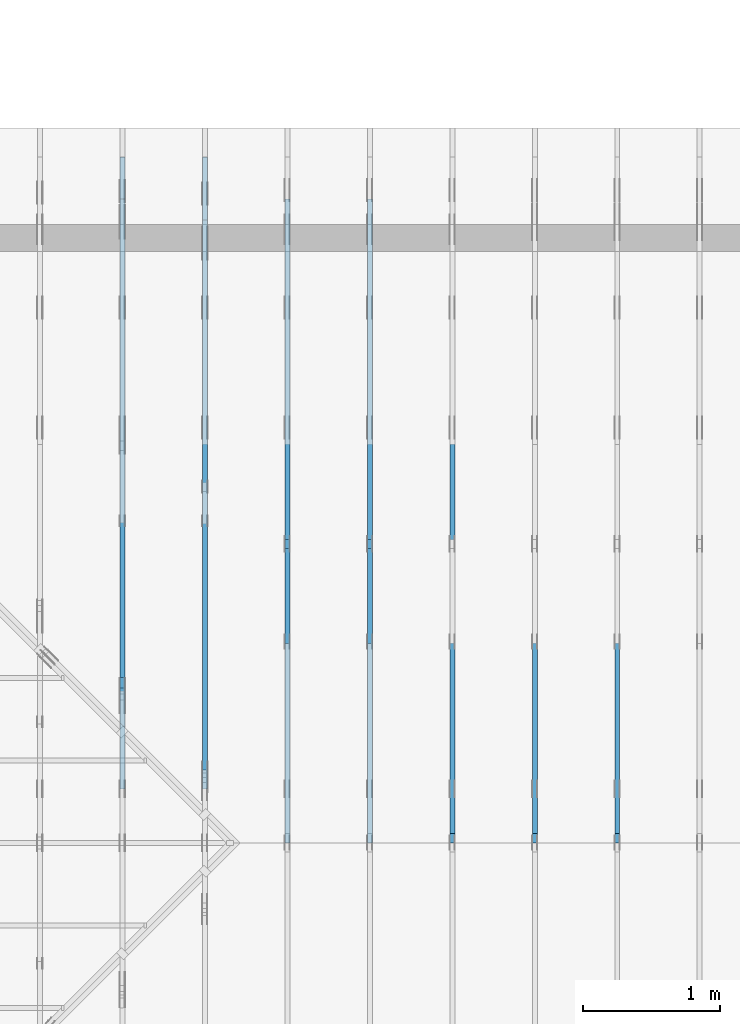
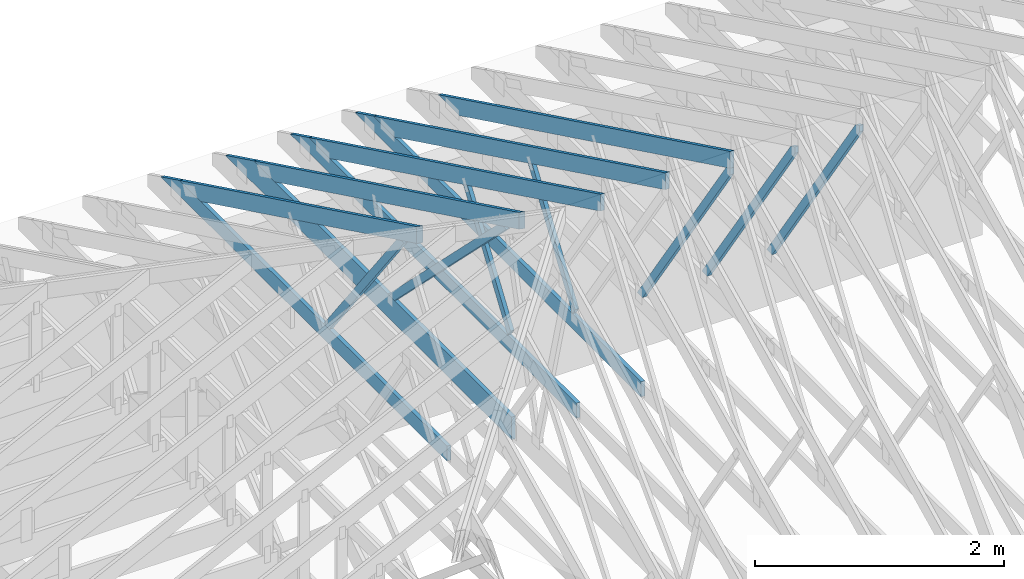
# One storey, part 10 of 159: 16 members, 7 elements without a shape of their own.
"""IFC2X3 building model written with IfcOpenShell, lengths in millimetres."""

from ifc_helpers import new_model, si_unit, frame, origin, origin_with_axes, origin_2d, place, context, project, spatial, faceted_brep, element, aggregate, save


model = new_model("IFC2X3")

# Units and contexts
model_context = context("Model", 3, precision=1e-05, world=origin())
plan_context = context("Plan", 2, precision=1e-05, world=origin_2d())
ifc_project = project(units=[si_unit("LENGTHUNIT", "METRE", prefix="MILLI"), si_unit("AREAUNIT", "SQUARE_METRE"), si_unit("VOLUMEUNIT", "CUBIC_METRE"), si_unit("SOLIDANGLEUNIT", "STERADIAN"), si_unit("PLANEANGLEUNIT", "RADIAN"), si_unit("MASSUNIT", "GRAM"), si_unit("TIMEUNIT", "SECOND"), si_unit("THERMODYNAMICTEMPERATUREUNIT", "DEGREE_CELSIUS"), si_unit("LUMINOUSINTENSITYUNIT", "LUMEN")], contexts=[model_context, plan_context])

# Site, building, storey
site_placement = place(None, origin_with_axes())
site = spatial("IfcSite", under=ifc_project, at=site_placement, CompositionType="ELEMENT")
building_placement = place(site_placement, origin_with_axes())
building = spatial("IfcBuilding", under=site, at=building_placement, Name="Plan 1", CompositionType="ELEMENT")
storey_placement = place(building_placement, origin_with_axes())
storey = spatial("IfcBuildingStorey", under=building, at=storey_placement, Name="Etasje 1", CompositionType="ELEMENT", Elevation=0.0)

# Assembly, member
assembly_1_placement = place(storey_placement, frame((7275.0222614047525, 9699.99999999999, 1.1021457184401395e-15), z_axis=(-1.0, 1.836909530733566e-16, 6.123031769111886e-17), x_axis=(-1.836909530733566e-16, -1.0, 0.0)))
assembly_1 = element("IfcElementAssembly", 1, at=assembly_1_placement, inside=storey, Name="T2 (90)", AssemblyPlace="FACTORY", PredefinedType="TRUSS")
member_1_placement = place(assembly_1_placement, frame((5169.864827117615, 2512.139275987297, -36.0), z_axis=(0.0, 0.0, 1.0), x_axis=(-0.564247505007381, -0.8256056886268078, 0.0)))
member_1 = element("IfcMember", 2, at=member_1_placement, Name="T2-D10", context=model_context, shape_type="Brep", body=[
    faceted_brep([(2543.525473098112, 73.00019205182707, 36.0), (53.406771110823684, 73.00019205182707, 36.0), (0.0, 36.5000932239891, 36.0), (64.12142578859857, 0.00011835385657832376, 36.0), (2593.4163311647667, 0.00011835385657832376, 36.0), (53.406771110823684, 73.00019205182707, 6.540227123945206e-15), (2543.525473098112, 73.00019205182707, 3.114817455465016e-13), (2593.4163311647667, 0.00011835385657832376, 3.175914117251092e-13), (64.12142578859857, 0.00011835385657832376, 7.852350543686785e-15), (0.0, 36.5000932239891, 0.0), (8.990056994662154e-05, 36.50009815631665, 3.944304526105059e-31), (8.990056994662154e-05, 36.50009815631665, 36.0), (53.40680834923387, 73.00009815680099, 36.0), (53.40680834923387, 73.00009815680099, 7.888609052210118e-31), (64.12149423256596, 9.815680185809583e-05, 6.171430365172586e-31), (64.12149423256596, 9.815680186164855e-05, 36.0), (8.990056995195062e-05, 36.50009815631667, 36.0), (8.990056995017426e-05, 36.50009815631666, -3.3878954237129854e-31), (2593.4162640810096, 9.815680364966906e-05, 2.3313020864942917e-30), (2593.4162640810096, 9.815680365187335e-05, 36.0), (64.12149423256596, 9.815680187001689e-05, 36.0), (64.12149423256596, 9.81568018678126e-05, 5.76409767496333e-32), (2543.5255372692222, 73.00009815680278, 0.0), (2543.5255372692222, 73.00009815680278, 36.0), (2593.4162640810096, 9.815680414249073e-05, 36.0), (2593.4162640810096, 9.815680414249073e-05, 0.0), (53.40680834923387, 73.00009815680097, 7.888609052210118e-31), (53.40680834923387, 73.00009815680097, 36.0), (2543.525537269222, 73.00009815680359, 36.0), (2543.525537269222, 73.00009815680359, 4.9698237028923744e-29)], [[[0, 1, 2, 3, 4]], [[5, 6, 7, 8, 9]], [[10, 11, 12, 13]], [[14, 15, 16, 17]], [[18, 19, 20, 21]], [[22, 23, 24, 25]], [[26, 27, 28, 29]]]),
])
aggregate(assembly_1, [member_1])

assembly_2_placement = place(storey_placement, frame((6675.0222614047525, 9699.99999999999, 1.1021457184401395e-15), z_axis=(-1.0, 1.836909530733566e-16, 6.123031769111886e-17), x_axis=(-1.836909530733566e-16, -1.0, 0.0)))
assembly_2 = element("IfcElementAssembly", 3, at=assembly_2_placement, inside=storey, Name="T2 (89)", AssemblyPlace="FACTORY", PredefinedType="TRUSS")
member_2_placement = place(assembly_2_placement, frame((5169.864827117615, 2512.139275987297, -36.0), z_axis=(0.0, 0.0, 1.0), x_axis=(-0.564247505007381, -0.8256056886268078, 0.0)))
member_2 = element("IfcMember", 4, at=member_2_placement, Name="T2-D10", context=model_context, shape_type="Brep", body=[
    faceted_brep([(2543.525473098112, 73.00019205182707, 36.0), (53.406771110823684, 73.00019205182707, 36.0), (0.0, 36.5000932239891, 36.0), (64.12142578859857, 0.00011835385657832376, 36.0), (2593.4163311647667, 0.00011835385657832376, 36.0), (53.406771110823684, 73.00019205182707, 6.540227123945206e-15), (2543.525473098112, 73.00019205182707, 3.114817455465016e-13), (2593.4163311647667, 0.00011835385657832376, 3.175914117251092e-13), (64.12142578859857, 0.00011835385657832376, 7.852350543686785e-15), (0.0, 36.5000932239891, 0.0), (8.990056994662154e-05, 36.50009815631665, 3.944304526105059e-31), (8.990056994662154e-05, 36.50009815631665, 36.0), (53.40680834923387, 73.00009815680099, 36.0), (53.40680834923387, 73.00009815680099, 7.888609052210118e-31), (64.12149423256596, 9.815680185809583e-05, 6.171430365172586e-31), (64.12149423256596, 9.815680186164855e-05, 36.0), (8.990056995195062e-05, 36.50009815631667, 36.0), (8.990056995017426e-05, 36.50009815631666, -3.3878954237129854e-31), (2593.4162640810096, 9.815680364966906e-05, 2.3313020864942917e-30), (2593.4162640810096, 9.815680365187335e-05, 36.0), (64.12149423256596, 9.815680187001689e-05, 36.0), (64.12149423256596, 9.81568018678126e-05, 5.76409767496333e-32), (2543.5255372692222, 73.00009815680278, 0.0), (2543.5255372692222, 73.00009815680278, 36.0), (2593.4162640810096, 9.815680414249073e-05, 36.0), (2593.4162640810096, 9.815680414249073e-05, 0.0), (53.40680834923387, 73.00009815680097, 7.888609052210118e-31), (53.40680834923387, 73.00009815680097, 36.0), (2543.525537269222, 73.00009815680359, 36.0), (2543.525537269222, 73.00009815680359, 4.9698237028923744e-29)], [[[0, 1, 2, 3, 4]], [[5, 6, 7, 8, 9]], [[10, 11, 12, 13]], [[14, 15, 16, 17]], [[18, 19, 20, 21]], [[22, 23, 24, 25]], [[26, 27, 28, 29]]]),
])
aggregate(assembly_2, [member_2])

# Assembly, members
assembly_3_placement = place(storey_placement, frame((5475.0222614047525, 9699.99999999999, 1.1021457184401395e-15), z_axis=(-1.0, 1.836909530733566e-16, 6.123031769111886e-17), x_axis=(-1.836909530733566e-16, -1.0, 0.0)))
assembly_3 = element("IfcElementAssembly", 5, at=assembly_3_placement, inside=storey, Name="T1 (87)", AssemblyPlace="FACTORY", PredefinedType="TRUSS")
member_3_placement = place(assembly_3_placement, frame((579.5051980003889, 237.97847286708455, -36.00000000000001), z_axis=(0.0, 0.0, 1.0), x_axis=(0.8987940462991671, 0.43837114678907757, 0.0)))
member_3 = element("IfcMember", 6, at=member_3_placement, Name="T1-O3", context=model_context, shape_type="Brep", body=[
    faceted_brep([(5212.955369683486, 148.00001471731446, 36.0), (1.573016606926103e-05, 148.00001471731446, 36.0), (303.44498744329735, 0.0, 36.0), (5140.770967673589, 0.0, 36.0), (1.573016606926103e-05, 148.00001471731446, 1.9263261315098228e-21), (5212.955369683486, 148.00001471731446, 6.383818267906877e-13), (5140.770967673589, 0.0, 6.295420790558688e-13), (303.44498744329735, 0.0, 3.716006596586134e-14), (303.44496855236554, 9.213724169399029e-06, 8.404281481000962e-31), (303.44496855236554, 9.213724169399029e-06, 36.0), (0.0, 148.000009213056, 36.0), (0.0, 148.000009213056, -1.9992365007213114e-31), (5140.770891984262, 9.214032787493993e-06, -1.5668329852774188e-28), (5140.770891984262, 9.214032789698284e-06, 36.0), (303.4449685523656, 9.213724336859708e-06, 36.0), (303.4449685523656, 9.213724334655416e-06, -9.24856583218491e-30), (5212.955315091657, 148.00000921330889, -5.793884668474286e-29), (5212.955315091657, 148.00000921330889, 36.0), (5140.770891984262, 9.214030342263868e-06, 36.0), (5140.770891984262, 9.214030342263868e-06, -5.743143320920135e-29), (0.0, 148.000009213056, 0.0), (0.0, 148.000009213056, 36.0), (5212.955315091657, 148.00000921330917, 36.0), (5212.955315091657, 148.00000921330917, 9.466330862652142e-30)], [[[0, 1, 2, 3]], [[4, 5, 6, 7]], [[8, 9, 10, 11]], [[12, 13, 14, 15]], [[16, 17, 18, 19]], [[20, 21, 22, 23]]]),
])
member_4_placement = place(assembly_3_placement, frame((4808.81787109375, 371.0000000000005, -36.0), z_axis=(0.0, 0.0, 1.0), x_axis=(-1.0, 1.2246063538223773e-16, 0.0)))
member_4 = element("IfcMember", 7, at=member_4_placement, Name="T1-U35", context=model_context, shape_type="Brep", body=[
    faceted_brep([(4597.636581420898, 148.00000000000105, 36.0), (0.0, 148.00000000000105, 36.0), (0.0, 5.115907697472721e-13, 36.0), (4294.191589355469, 5.115907697472721e-13, 36.0), (0.0, 148.00000000000105, 0.0), (4597.636581420898, 148.00000000000105, 5.630294970174226e-13), (4294.191589355469, 5.115907697472721e-13, 5.25869430485532e-13), (0.0, 5.115907697472721e-13, 0.0), (0.00023664694708713796, 0.0, 0.0), (0.00023664694708934225, -2.6993892992798474e-31, 36.0), (0.00023664694710746643, 147.99999999999994, 36.0), (0.00023664694710526213, 147.99999999999994, -1.1097479173457682e-30), (4294.191606856883, -7.888042053292689e-13, 1.1094846280734072e-28), (4294.191606856883, -7.865999138923886e-13, 36.0), (0.00023664694708713796, 2.2041915808575547e-15, 36.0), (0.00023664694708713796, -9.985602272457245e-20, 6.114215994797155e-36), (4597.636575412006, 148.00000000000205, -2.5243548967072372e-29), (4597.636575412006, 148.00000000000205, 36.0), (4294.191606856883, 1.5916157281026244e-12, 36.0), (4294.191606856883, 1.5916157281026244e-12, -2.5243548967072372e-29), (0.00023664694708713796, 147.99999999999994, 0.0), (0.00023664694708713796, 147.99999999999994, 36.0), (4597.636575412005, 148.00000000000068, 36.0), (4597.636575412005, 148.00000000000068, -2.208810534618833e-29)], [[[0, 1, 2, 3]], [[4, 5, 6, 7]], [[8, 9, 10, 11]], [[12, 13, 14, 15]], [[16, 17, 18, 19]], [[20, 21, 22, 23]]]),
])
member_5_placement = place(assembly_3_placement, frame((2992.962039007774, 1415.1000197155186, -36.0), z_axis=(0.0, 0.0, 1.0), x_axis=(0.5642475050068997, -0.8256056886271368, 0.0)))
member_5 = element("IfcMember", 8, at=member_5_placement, Name="T1-D42", context=model_context, shape_type="Brep", body=[
    faceted_brep([(1236.1860950310158, 73.0001983605489, 36.0), (10.714657585100667, 73.0001983605489, 36.0), (2.9073682981106685e-06, 0.00014238622361517628, 36.0), (1264.647317839714, 0.00014238622361517628, 36.0), (10.714657585100667, 73.0001983605489, 1.3121237757745405e-15), (1236.1860950310158, 73.0001983605489, 1.513841346481855e-13), (1264.647317839714, 0.00014238622361517628, 1.5486951407709413e-13), (2.9073682981106685e-06, 0.00014238622361517628, 3.560381690768076e-22), (-1.0876495965808294e-15, 9.815680186891362e-05, 6.73106873190455e-32), (1.0932755894164925e-15, 9.815680186859351e-05, 36.0), (10.71468588481117, 73.00009815680141, 36.0), (10.714685884811168, 73.00009815680141, -5.004528960490232e-31), (1264.6473849234712, 9.81568027596822e-05, 5.682548008281813e-29), (1264.6473849234712, 9.815680276188649e-05, 36.0), (-1.5529013882837331e-30, 9.815680187095826e-05, 36.0), (0.0, 9.815680186875397e-05, 0.0), (1236.1860298813824, 73.00009815680414, 0.0), (1236.1860298813824, 73.00009815680414, 36.0), (1264.6473849234712, 9.81568037445868e-05, 36.0), (1264.6473849234712, 9.81568037445868e-05, 1.262177448353619e-29), (10.714685884811162, 73.00009815680141, 0.0), (10.714685884811162, 73.0000981568014, 36.0), (1236.1860298813824, 73.00009815680406, 36.0), (1236.1860298813824, 73.00009815680406, -5.5220263365470826e-30)], [[[0, 1, 2, 3]], [[4, 5, 6, 7]], [[8, 9, 10, 11]], [[12, 13, 14, 15]], [[16, 17, 18, 19]], [[20, 21, 22, 23]]]),
])
aggregate(assembly_3, [member_3, member_4, member_5])

assembly_4_placement = place(storey_placement, frame((4875.0222614047525, 9699.99999999999, 1.1021457184401395e-15), z_axis=(-1.0, 1.836909530733566e-16, 6.123031769111886e-17), x_axis=(-1.836909530733566e-16, -1.0, 0.0)))
assembly_4 = element("IfcElementAssembly", 9, at=assembly_4_placement, inside=storey, Name="T1 (86)", AssemblyPlace="FACTORY", PredefinedType="TRUSS")
member_6_placement = place(assembly_4_placement, frame((579.5051980003889, 237.97847286708455, -36.00000000000001), z_axis=(0.0, 0.0, 1.0), x_axis=(0.8987940462991671, 0.43837114678907757, 0.0)))
member_6 = element("IfcMember", 10, at=member_6_placement, Name="T1-O3", context=model_context, shape_type="Brep", body=[
    faceted_brep([(5212.955369683486, 148.00001471731446, 36.0), (1.573016606926103e-05, 148.00001471731446, 36.0), (303.44498744329735, 0.0, 36.0), (5140.770967673589, 0.0, 36.0), (1.573016606926103e-05, 148.00001471731446, 1.9263261315098228e-21), (5212.955369683486, 148.00001471731446, 6.383818267906877e-13), (5140.770967673589, 0.0, 6.295420790558688e-13), (303.44498744329735, 0.0, 3.716006596586134e-14), (303.44496855236554, 9.213724169399029e-06, 8.404281481000962e-31), (303.44496855236554, 9.213724169399029e-06, 36.0), (0.0, 148.000009213056, 36.0), (0.0, 148.000009213056, -1.9992365007213114e-31), (5140.770891984262, 9.214032787493993e-06, -1.5668329852774188e-28), (5140.770891984262, 9.214032789698284e-06, 36.0), (303.4449685523656, 9.213724336859708e-06, 36.0), (303.4449685523656, 9.213724334655416e-06, -9.24856583218491e-30), (5212.955315091657, 148.00000921330889, -5.793884668474286e-29), (5212.955315091657, 148.00000921330889, 36.0), (5140.770891984262, 9.214030342263868e-06, 36.0), (5140.770891984262, 9.214030342263868e-06, -5.743143320920135e-29), (0.0, 148.000009213056, 0.0), (0.0, 148.000009213056, 36.0), (5212.955315091657, 148.00000921330917, 36.0), (5212.955315091657, 148.00000921330917, 9.466330862652142e-30)], [[[0, 1, 2, 3]], [[4, 5, 6, 7]], [[8, 9, 10, 11]], [[12, 13, 14, 15]], [[16, 17, 18, 19]], [[20, 21, 22, 23]]]),
])
member_7_placement = place(assembly_4_placement, frame((4808.81787109375, 371.0000000000005, -36.0), z_axis=(0.0, 0.0, 1.0), x_axis=(-1.0, 1.2246063538223773e-16, 0.0)))
member_7 = element("IfcMember", 11, at=member_7_placement, Name="T1-U35", context=model_context, shape_type="Brep", body=[
    faceted_brep([(4597.636581420898, 148.00000000000105, 36.0), (0.0, 148.00000000000105, 36.0), (0.0, 5.115907697472721e-13, 36.0), (4294.191589355469, 5.115907697472721e-13, 36.0), (0.0, 148.00000000000105, 0.0), (4597.636581420898, 148.00000000000105, 5.630294970174226e-13), (4294.191589355469, 5.115907697472721e-13, 5.25869430485532e-13), (0.0, 5.115907697472721e-13, 0.0), (0.00023664694708713796, 0.0, 0.0), (0.00023664694708934225, -2.6993892992798474e-31, 36.0), (0.00023664694710746643, 147.99999999999994, 36.0), (0.00023664694710526213, 147.99999999999994, -1.1097479173457682e-30), (4294.191606856883, -7.888042053292689e-13, 1.1094846280734072e-28), (4294.191606856883, -7.865999138923886e-13, 36.0), (0.00023664694708713796, 2.2041915808575547e-15, 36.0), (0.00023664694708713796, -9.985602272457245e-20, 6.114215994797155e-36), (4597.636575412006, 148.00000000000205, -2.5243548967072372e-29), (4597.636575412006, 148.00000000000205, 36.0), (4294.191606856883, 1.5916157281026244e-12, 36.0), (4294.191606856883, 1.5916157281026244e-12, -2.5243548967072372e-29), (0.00023664694708713796, 147.99999999999994, 0.0), (0.00023664694708713796, 147.99999999999994, 36.0), (4597.636575412005, 148.00000000000068, 36.0), (4597.636575412005, 148.00000000000068, -2.208810534618833e-29)], [[[0, 1, 2, 3]], [[4, 5, 6, 7]], [[8, 9, 10, 11]], [[12, 13, 14, 15]], [[16, 17, 18, 19]], [[20, 21, 22, 23]]]),
])
member_8_placement = place(assembly_4_placement, frame((2992.962039007774, 1415.1000197155186, -36.0), z_axis=(0.0, 0.0, 1.0), x_axis=(0.5642475050068997, -0.8256056886271368, 0.0)))
member_8 = element("IfcMember", 12, at=member_8_placement, Name="T1-D42", context=model_context, shape_type="Brep", body=[
    faceted_brep([(1236.1860950310158, 73.0001983605489, 36.0), (10.714657585100667, 73.0001983605489, 36.0), (2.9073682981106685e-06, 0.00014238622361517628, 36.0), (1264.647317839714, 0.00014238622361517628, 36.0), (10.714657585100667, 73.0001983605489, 1.3121237757745405e-15), (1236.1860950310158, 73.0001983605489, 1.513841346481855e-13), (1264.647317839714, 0.00014238622361517628, 1.5486951407709413e-13), (2.9073682981106685e-06, 0.00014238622361517628, 3.560381690768076e-22), (-1.0876495965808294e-15, 9.815680186891362e-05, 6.73106873190455e-32), (1.0932755894164925e-15, 9.815680186859351e-05, 36.0), (10.71468588481117, 73.00009815680141, 36.0), (10.714685884811168, 73.00009815680141, -5.004528960490232e-31), (1264.6473849234712, 9.81568027596822e-05, 5.682548008281813e-29), (1264.6473849234712, 9.815680276188649e-05, 36.0), (-1.5529013882837331e-30, 9.815680187095826e-05, 36.0), (0.0, 9.815680186875397e-05, 0.0), (1236.1860298813824, 73.00009815680414, 0.0), (1236.1860298813824, 73.00009815680414, 36.0), (1264.6473849234712, 9.81568037445868e-05, 36.0), (1264.6473849234712, 9.81568037445868e-05, 1.262177448353619e-29), (10.714685884811162, 73.00009815680141, 0.0), (10.714685884811162, 73.0000981568014, 36.0), (1236.1860298813824, 73.00009815680406, 36.0), (1236.1860298813824, 73.00009815680406, -5.5220263365470826e-30)], [[[0, 1, 2, 3]], [[4, 5, 6, 7]], [[8, 9, 10, 11]], [[12, 13, 14, 15]], [[16, 17, 18, 19]], [[20, 21, 22, 23]]]),
])
aggregate(assembly_4, [member_6, member_7, member_8])

assembly_5_placement = place(storey_placement, frame((3675.02226140475, 9699.999999999993, 1.1021457184401395e-15), z_axis=(-1.0, 1.836909530733566e-16, 6.123031769111886e-17), x_axis=(-1.836909530733566e-16, -1.0, 0.0)))
assembly_5 = element("IfcElementAssembly", 13, at=assembly_5_placement, inside=storey, Name="V4 (5)", AssemblyPlace="FACTORY", PredefinedType="TRUSS")
member_9_placement = place(assembly_5_placement, frame((579.5050503991354, 237.97841077039223, -36.00000021758226), z_axis=(0.0, 0.0, 1.0), x_axis=(0.8987940462991671, 0.4383711467890776, 0.0)))
member_9 = element("IfcMember", 14, at=member_9_placement, Name="V4-O19", context=model_context, shape_type="Brep", body=[
    faceted_brep([(4278.493462042187, 148.00000083081522, 2.2533295123139396e-06), (4238.439795044849, 147.99999513788975, 35.99999718737217), (4166.25537109375, 3.211918055967544e-07, 36.0000002175816), (4206.309041036284, 0.0, -2.2737367544323206e-13), (0.00034107695569218777, 148.00000032212867, 2.1758226154133808e-07), (0.00034107695569218777, 148.0000003221289, 36.00000021758226), (4238.439794201957, 148.00000032212958, 36.00000021758226), (4278.493463177787, 148.00000032212935, 2.1758226154133808e-07), (303.4451284368916, 3.217305817315719e-07, 2.1758226154133808e-07), (303.4451284368916, 3.217305817315719e-07, 36.00000021758226), (0.0001567237602841942, 148.00000186267084, 36.00000021758226), (0.0001567237602841942, 148.00000186267084, 2.1758226154133808e-07), (4206.309040950855, 3.211852784919212e-07, 2.1758226154133806e-07), (4166.255371975025, 3.2118597550380613e-07, 36.00000021758226), (303.4450272789793, 3.2118668506711987e-07, 36.00000021758226), (303.4450272789793, 3.211859954127316e-07, 2.1758226154133806e-07), (4238.439796447754, 148.00000032119215, 36.00000021758226), (0.0, 148.00000032119215, 36.00000021758226), (303.44506835937534, 3.2173045383387944e-07, 36.00000021758226), (4166.25537109375, 3.2173045383387944e-07, 36.00000021758226), (0.00029999656635482097, 148.0000003210621, 2.1758226154137482e-07), (4278.493464059067, 148.0000003210621, 2.1758278548836617e-07), (4206.309038705063, 3.221389306418132e-07, 2.175827766486156e-07), (303.44512421531647, 3.221389306418132e-07, 2.175822987014208e-07)], [[[0, 1, 2, 3]], [[4, 5, 6, 7]], [[8, 9, 10, 11]], [[12, 13, 14, 15]], [[16, 17, 18, 19]], [[20, 21, 22, 23]]]),
])
member_10_placement = place(assembly_5_placement, frame((4808.81787109375, 371.00000000000045, -36.0), z_axis=(0.0, 0.0, 1.0), x_axis=(-1.0, 1.2246063538223773e-16, 0.0)))
member_10 = element("IfcMember", 15, at=member_10_placement, Name="V4-U35", context=model_context, shape_type="Brep", body=[
    faceted_brep([(4597.636581420898, 148.000000000001, 36.0), (0.0, 148.000000000001, 36.0), (0.0, 4.547473508864641e-13, 36.0), (4294.191589355469, 4.547473508864641e-13, 36.0), (0.0, 148.000000000001, 0.0), (4597.636581420898, 148.000000000001, 5.630294970174226e-13), (4294.191589355469, 4.547473508864641e-13, 5.25869430485532e-13), (0.0, 4.547473508864641e-13, 0.0), (0.00023664720265514916, 0.0, 0.0), (0.00023664720265735345, -2.6993892992798474e-31, 36.0), (0.00023664720267547762, 147.99999999999997, 36.0), (0.00023664720267327333, 147.99999999999997, -1.1097479173457682e-30), (4294.191606856883, -7.888042021967641e-13, 1.0746792202003985e-28), (4294.191606856883, -7.865999107598839e-13, 36.0), (0.00023664720265514916, 2.2041947133152905e-15, 36.0), (0.00023664720265514916, -9.672356498864107e-20, 5.922414612472074e-36), (4597.636575412006, 148.00000000000205, -2.5243548967072372e-29), (4597.636575412006, 148.00000000000205, 36.0), (4294.191606856883, 1.5916157281026244e-12, 36.0), (4294.191606856883, 1.5916157281026244e-12, -2.5243548967072372e-29), (0.00023664720265514916, 147.99999999999997, 0.0), (0.00023664720265514916, 147.99999999999997, 36.0), (4597.636575412005, 148.0000000000007, 36.0), (4597.636575412005, 148.0000000000007, -1.735493991486226e-29)], [[[0, 1, 2, 3]], [[4, 5, 6, 7]], [[8, 9, 10, 11]], [[12, 13, 14, 15]], [[16, 17, 18, 19]], [[20, 21, 22, 23]]]),
])
member_11_placement = place(assembly_5_placement, frame((4059.4251313662976, 1985.4372025225302, -36.0), z_axis=(0.0, 0.0, 1.0), x_axis=(-0.6063173886097647, -0.7952227513530002, 0.0)))
member_11 = element("IfcMember", 16, at=member_11_placement, Name="V4-D15", context=model_context, shape_type="Brep", body=[
    faceted_brep([(1974.5109078483338, 73.00006009782305, 36.0), (0.0, 73.00006009782305, 36.0), (27.829464846387054, 36.50014994479375, 36.0), (100.47664470704603, 0.0, 36.0), (2030.1696895144019, 0.0, 36.0), (0.0, 73.00006009782305, 0.0), (1974.5109078483338, 73.00006009782305, 2.41799860344266e-13), (2030.1696895144019, 0.0, 2.486158701116939e-13), (100.47664470704603, 0.0, 1.230443375190021e-14), (27.829464846387054, 36.50014994479375, 3.4080139474362076e-15), (27.82957137384347, 36.500105758965454, -7.489347741635244e-32), (27.82957137384347, 36.500105758965454, 36.0), (0.00015546921986242523, 73.00010575890862, 36.0), (0.00015546921986242523, 73.00010575890862, -3.5776845442291834e-31), (100.47658861684019, 0.00010575890901520779, 3.1554436208840472e-30), (100.47658861684019, 0.00010575890901520779, 36.0), (27.829571373843464, 36.50010575896545, 36.0), (27.829571373843464, 36.50010575896545, 3.944304526105059e-31), (2030.169704843382, 0.0001057589121254757, 7.0779866432503e-30), (2030.169704843382, 0.00010575891212767999, 36.0), (100.47658861684022, 0.0001057589090543236, 36.0), (100.47658861684022, 0.0001057589090521193, 3.5030183044334883e-31), (1974.5108730340485, 73.00010575891031, -2.524354896707238e-29), (1974.5108730340485, 73.00010575891031, 36.0), (2030.1697048433816, 0.00010575891235475865, 36.0), (2030.1697048433816, 0.00010575891235475865, -2.524354896707238e-29), (0.00015546921986242523, 73.0001057589086, 0.0), (0.00015546921986242523, 73.0001057589086, 36.0), (1974.510873034049, 73.00010575891068, 36.0), (1974.510873034049, 73.00010575891068, 1.5777218104420236e-29)], [[[0, 1, 2, 3, 4]], [[5, 6, 7, 8, 9]], [[10, 11, 12, 13]], [[14, 15, 16, 17]], [[18, 19, 20, 21]], [[22, 23, 24, 25]], [[26, 27, 28, 29]]]),
])
aggregate(assembly_5, [member_9, member_10, member_11])

assembly_6_placement = place(storey_placement, frame((6075.0222614047525, 9699.99999999999, 1.1021457184401395e-15), z_axis=(-1.0, 1.836909530733566e-16, 6.123031769111886e-17), x_axis=(-1.836909530733566e-16, -1.0, 0.0)))
assembly_6 = element("IfcElementAssembly", 17, at=assembly_6_placement, inside=storey, Name="T1 (88)", AssemblyPlace="FACTORY", PredefinedType="TRUSS")
member_12_placement = place(assembly_6_placement, frame((579.5051980003889, 237.97847286708455, -36.00000000000001), z_axis=(0.0, 0.0, 1.0), x_axis=(0.8987940462991671, 0.43837114678907757, 0.0)))
member_12 = element("IfcMember", 18, at=member_12_placement, Name="T1-O3", context=model_context, shape_type="Brep", body=[
    faceted_brep([(5212.955369683486, 148.00001471731446, 36.0), (1.573016606926103e-05, 148.00001471731446, 36.0), (303.44498744329735, 0.0, 36.0), (5140.770967673589, 0.0, 36.0), (1.573016606926103e-05, 148.00001471731446, 1.9263261315098228e-21), (5212.955369683486, 148.00001471731446, 6.383818267906877e-13), (5140.770967673589, 0.0, 6.295420790558688e-13), (303.44498744329735, 0.0, 3.716006596586134e-14), (303.44496855236554, 9.213724169399029e-06, 8.404281481000962e-31), (303.44496855236554, 9.213724169399029e-06, 36.0), (0.0, 148.000009213056, 36.0), (0.0, 148.000009213056, -1.9992365007213114e-31), (5140.770891984262, 9.214032787493993e-06, -1.5668329852774188e-28), (5140.770891984262, 9.214032789698284e-06, 36.0), (303.4449685523656, 9.213724336859708e-06, 36.0), (303.4449685523656, 9.213724334655416e-06, -9.24856583218491e-30), (5212.955315091657, 148.00000921330889, -5.793884668474286e-29), (5212.955315091657, 148.00000921330889, 36.0), (5140.770891984262, 9.214030342263868e-06, 36.0), (5140.770891984262, 9.214030342263868e-06, -5.743143320920135e-29), (0.0, 148.000009213056, 0.0), (0.0, 148.000009213056, 36.0), (5212.955315091657, 148.00000921330917, 36.0), (5212.955315091657, 148.00000921330917, 9.466330862652142e-30)], [[[0, 1, 2, 3]], [[4, 5, 6, 7]], [[8, 9, 10, 11]], [[12, 13, 14, 15]], [[16, 17, 18, 19]], [[20, 21, 22, 23]]]),
])
member_13_placement = place(assembly_6_placement, frame((5169.864827117615, 2512.139275987297, -36.0), z_axis=(0.0, 0.0, 1.0), x_axis=(-0.564247505007381, -0.8256056886268078, 0.0)))
member_13 = element("IfcMember", 19, at=member_13_placement, Name="T1-D10", context=model_context, shape_type="Brep", body=[
    faceted_brep([(2543.525473098112, 73.00019205182707, 36.0), (53.406771110823684, 73.00019205182707, 36.0), (0.0, 36.5000932239891, 36.0), (64.12142578859857, 0.00011835385657832376, 36.0), (2593.4163311647667, 0.00011835385657832376, 36.0), (53.406771110823684, 73.00019205182707, 6.540227123945206e-15), (2543.525473098112, 73.00019205182707, 3.114817455465016e-13), (2593.4163311647667, 0.00011835385657832376, 3.175914117251092e-13), (64.12142578859857, 0.00011835385657832376, 7.852350543686785e-15), (0.0, 36.5000932239891, 0.0), (8.990056994662154e-05, 36.50009815631665, 3.944304526105059e-31), (8.990056994662154e-05, 36.50009815631665, 36.0), (53.40680834923387, 73.00009815680099, 36.0), (53.40680834923387, 73.00009815680099, 7.888609052210118e-31), (64.12149423256596, 9.815680185809583e-05, 6.171430365172586e-31), (64.12149423256596, 9.815680186164855e-05, 36.0), (8.990056995195062e-05, 36.50009815631667, 36.0), (8.990056995017426e-05, 36.50009815631666, -3.3878954237129854e-31), (2593.4162640810096, 9.815680364966906e-05, 2.3313020864942917e-30), (2593.4162640810096, 9.815680365187335e-05, 36.0), (64.12149423256596, 9.815680187001689e-05, 36.0), (64.12149423256596, 9.81568018678126e-05, 5.76409767496333e-32), (2543.5255372692222, 73.00009815680278, 0.0), (2543.5255372692222, 73.00009815680278, 36.0), (2593.4162640810096, 9.815680414249073e-05, 36.0), (2593.4162640810096, 9.815680414249073e-05, 0.0), (53.40680834923387, 73.00009815680097, 7.888609052210118e-31), (53.40680834923387, 73.00009815680097, 36.0), (2543.525537269222, 73.00009815680359, 36.0), (2543.525537269222, 73.00009815680359, 4.9698237028923744e-29)], [[[0, 1, 2, 3, 4]], [[5, 6, 7, 8, 9]], [[10, 11, 12, 13]], [[14, 15, 16, 17]], [[18, 19, 20, 21]], [[22, 23, 24, 25]], [[26, 27, 28, 29]]]),
])
aggregate(assembly_6, [member_12, member_13])

assembly_7_placement = place(storey_placement, frame((4275.022261406632, 9700.000260373617, 1.1021457184401395e-15), z_axis=(-0.999999999895379, 1.4465201327097478e-05, 6.123031769111886e-17), x_axis=(-1.4465201327097478e-05, -0.999999999895379, 0.0)))
assembly_7 = element("IfcElementAssembly", 20, at=assembly_7_placement, inside=storey, Name="V13 (6)", AssemblyPlace="FACTORY", PredefinedType="TRUSS")
member_14_placement = place(assembly_7_placement, frame((733.2779410876435, 312.9784611195521, -36.00000022476441), z_axis=(0.0, 0.0, 1.0), x_axis=(0.8987940463172374, 0.43837114675202815, 0.0)))
member_14 = element("IfcMember", 21, at=member_14_placement, Name="V13-O10", context=model_context, shape_type="Brep", body=[
    faceted_brep([(4774.886493174539, 147.99999920373955, 1.9469061953714117e-06), (4734.833984521883, 148.0000005512403, 36.00000033412016), (4662.649561274524, 1.0800249583553523e-11, 36.000000224764335), (4702.702072872347, 4.993504489902989e-07, 0.0), (0.0, 148.0000000005835, 2.247644061981191e-07), (0.0, 148.0000000005835, 36.000000224764406), (4734.833984375, 148.0000000005832, 36.000000224764406), (4774.886493682861, 148.0000000005832, 2.247644061981191e-07), (303.44501426475284, 1.1387868426027126e-09, 2.247644061981191e-07), (303.44501426475284, 1.1387868426027126e-09, 36.000000224764406), (4.254552096938369e-05, 148.0000015295706, 36.000000224764406), (4.254552096938369e-05, 148.0000015295706, 2.247644061981191e-07), (4702.702072378745, -5.913893076547825e-13, 2.247644061981191e-07), (4662.649563070883, -1.0374632619163257e-12, 36.000000224764406), (303.44523644124456, -2.3671686451622794e-13, 36.000000224764406), (303.44523644124456, 2.1671437335305603e-13, 2.247644061981191e-07), (4734.833986628528, 148.00000000001046, 36.000000224764406), (0.0001472120250127773, 148.00000000001046, 36.000000224764406), (303.4449714307748, 1.139028427132871e-09, 36.000000224764406), (4662.649561274524, 1.139028427132871e-09, 36.000000224764406), (0.0002650104738677328, 148.00000000102642, 2.2476440619815156e-07), (4774.886495479224, 148.00000000102642, 2.2476499093375322e-07), (4702.70207012522, 5.798028723802418e-10, 2.2476498209400263e-07), (303.44508922922387, 5.798028723802418e-10, 2.2476444335819753e-07)], [[[0, 1, 2, 3]], [[4, 5, 6, 7]], [[8, 9, 10, 11]], [[12, 13, 14, 15]], [[16, 17, 18, 19]], [[20, 21, 22, 23]]]),
])
member_15_placement = place(assembly_7_placement, frame((4808.81787109375, 446.0000000000004, -36.0), z_axis=(0.0, 0.0, 1.0), x_axis=(-1.0, 1.2246063538223773e-16, 0.0)))
member_15 = element("IfcMember", 22, at=member_15_placement, Name="V13-U6", context=model_context, shape_type="Brep", body=[
    faceted_brep([(4597.636581420898, 223.00000000000094, 36.0), (0.0, 223.00000000000094, 36.0), (0.0, 3.979039320256561e-13, 36.0), (4140.4188232421875, 3.979039320256561e-13, 36.0), (0.0, 223.00000000000094, 0.0), (4597.636581420898, 223.00000000000094, 5.630294970174226e-13), (4140.4188232421875, 3.979039320256561e-13, 5.070383198428153e-13), (0.0, 3.979039320256561e-13, 0.0), (0.00023558177144877845, 0.0, 0.0), (0.00023558177145098275, -2.6993892992798474e-31, 36.0), (0.00023558177147829147, 222.99999999999994, 36.0), (0.00023558177147608718, 222.99999999999994, -1.6721224703723792e-30), (4140.418818669394, -7.605575306727232e-13, 1.0225782875340952e-28), (4140.418818669394, -7.583532392358429e-13, 36.0), (0.00023558177144877845, 2.2041964141590128e-15, 36.0), (0.00023558177144877845, -9.502272126614755e-20, 5.818271411000851e-36), (4597.636575389653, 223.00000000000023, 6.310887241768094e-29), (4597.636575389653, 223.00000000000023, 36.0), (4140.418818669395, 4.547473508864641e-13, 36.0), (4140.418818669395, 4.547473508864641e-13, 5.048709793414476e-29), (0.00023558177144877845, 222.99999999999994, 0.0), (0.00023558177144877845, 222.99999999999994, 36.0), (4597.636575389653, 223.00000000000068, 36.0), (4597.636575389653, 223.00000000000068, -1.4199496293978212e-29)], [[[0, 1, 2, 3]], [[4, 5, 6, 7]], [[8, 9, 10, 11]], [[12, 13, 14, 15]], [[16, 17, 18, 19]], [[20, 21, 22, 23]]]),
])
member_16_placement = place(assembly_7_placement, frame((4671.771087391019, 2285.5314915972804, -36.0), z_axis=(0.0, 0.0, 1.0), x_axis=(-0.7089439291787865, -0.7052648476143866, 0.0)))
member_16 = element("IfcMember", 23, at=member_16_placement, Name="V13-D9", context=model_context, shape_type="Brep", body=[
    faceted_brep([(2534.903919642319, 72.9999409876848, 36.0), (4.989675107935909e-05, 72.9999409876848, 36.0), (36.69032137994873, 36.50011257896949, 36.0), (143.59656876143708, 9.438235383640858e-05, 36.0), (2608.2846356907285, 9.438235383640858e-05, 36.0), (4.989675107935909e-05, 72.9999409876848, 6.1103878406876704e-21), (2534.903919642319, 72.9999409876848, 3.104259446323233e-13), (2608.2846356907285, 9.438235383640858e-05, 3.1941219374441507e-13), (143.59656876143708, 9.438235383640858e-05, 1.7584927049234774e-14), (36.69032137994873, 36.50011257896949, 4.493120068567022e-15), (36.69040574150403, 36.50000000117824, 7.888609052210118e-31), (36.69040574150404, 36.50000000117824, 36.0), (7.105427357601002e-15, 73.00000000000182, 36.0), (7.105427357601002e-15, 73.00000000000182, 0.0), (143.59677195287347, 5.897504706808832e-13, 5.5220263365470826e-30), (143.59677195287347, 5.897504706808832e-13, 36.0), (36.69040574150404, 36.500000001178236, 36.0), (36.69040574150404, 36.500000001178236, 7.888609052210118e-31), (2608.2846718075334, 2.427442222990011e-13, -1.4863305849051416e-29), (2608.2846718075334, 2.449485137358814e-13, 36.0), (143.5967719528735, 6.976893830885535e-13, 36.0), (143.5967719528735, 6.954850916516732e-13, -8.18285965309519e-31), (2534.9038603221607, 73.0, 0.0), (2534.9038603221607, 73.0, 36.0), (2608.2846718075334, 2.2737367544323206e-13, 36.0), (2608.2846718075334, 2.2737367544323206e-13, 1.262177448353619e-29), (0.0, 73.00000000000182, 0.0), (0.0, 73.00000000000182, 36.0), (2534.903860322161, 72.99999999999997, 36.0), (2534.903860322161, 72.99999999999997, 1.262177448353619e-29)], [[[0, 1, 2, 3, 4]], [[5, 6, 7, 8, 9]], [[10, 11, 12, 13]], [[14, 15, 16, 17]], [[18, 19, 20, 21]], [[22, 23, 24, 25]], [[26, 27, 28, 29]]]),
])
aggregate(assembly_7, [member_14, member_15, member_16])

save(model, "model.ifc")
